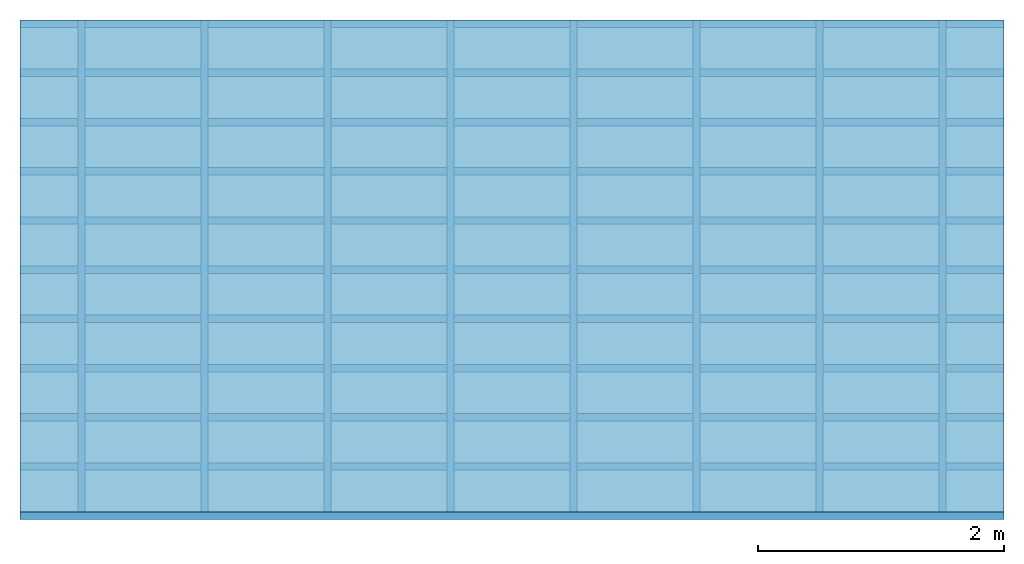
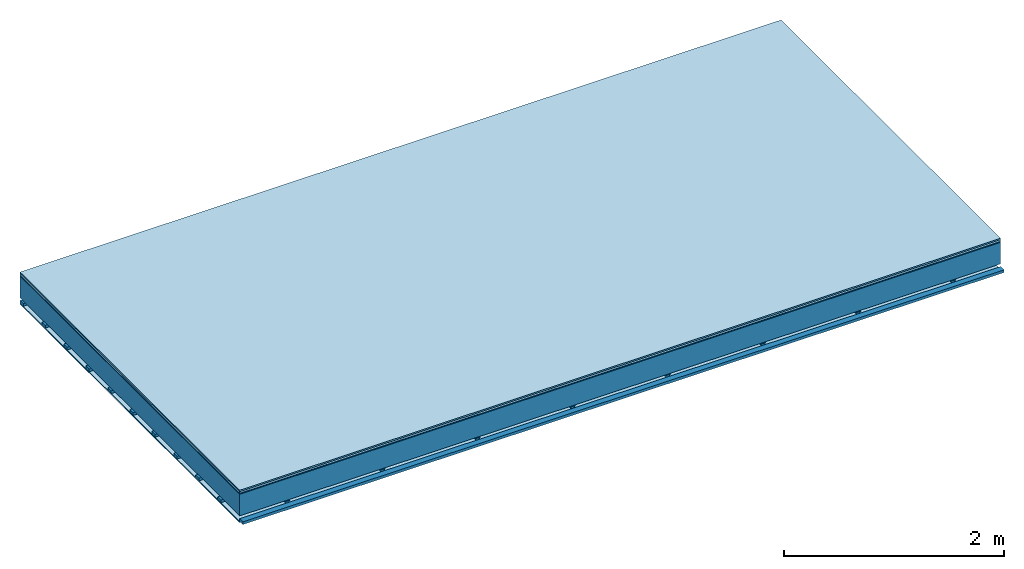
# One storey: 5 plates, 3 members, 1 element without a shape of its own.
"""IFC4 building model written with IfcOpenShell, lengths in metres."""

from ifc_helpers import new_model, si_unit, derived_unit, direction, frame, frame_2d, origin, origin_with_axes, place, context, project, spatial, polyline, rectangle, outline, extrude, material, layer, layer_set, type_object, element, aggregate, save


model = new_model("IFC4")

# Units and contexts
plan_context = context("Plan", 3, precision=1e-05, world=origin(), true_north=direction((0.0, 1.0)))
model_context = context("Model", 3, precision=1e-05, world=origin(), true_north=direction((0.0, 1.0)))
ifc_project = project(units=[si_unit("LENGTHUNIT", "METRE"), derived_unit("SOUNDPRESSUREUNIT", [(si_unit("PRESSUREUNIT", "PASCAL", prefix="MICRO"), 0)]), si_unit("ENERGYUNIT", "JOULE", prefix="MEGA"), si_unit("MASSUNIT", "GRAM", prefix="KILO"), derived_unit("THERMALTRANSMITTANCEUNIT", [(si_unit("POWERUNIT", "WATT"), 1), (si_unit("AREAUNIT", "SQUARE_METRE"), -1), (si_unit("THERMODYNAMICTEMPERATUREUNIT", "KELVIN"), -1)]), derived_unit("AREADENSITYUNIT", [(si_unit("MASSUNIT", "GRAM", prefix="KILO"), 1), (si_unit("AREAUNIT", "SQUARE_METRE"), -1)]), derived_unit("USERDEFINED", [(si_unit("ENERGYUNIT", "JOULE", prefix="MEGA"), 1), (si_unit("AREAUNIT", "SQUARE_METRE"), -1)])], contexts=[plan_context, model_context])

# Site, building, storey
site = spatial("IfcSite", under=ifc_project)
building_placement = place(None, origin())
building = spatial("IfcBuilding", under=site, at=building_placement)
storey_placement = place(building_placement, origin())
storey = spatial("IfcBuildingStorey", under=building, at=storey_placement)

# Slab, members, plates
ifc_material_1 = material(Category="11.013")
ifc_layer_1 = layer(ifc_material_1, 0.015, Name="Flooring")
ifc_material_2 = material(Category="03.007")
ifc_layer_2 = layer(ifc_material_2, 0.02, Name="On-material")
ifc_material_3 = material(Name="Wood fiber generic product", Category="10.009")
ifc_layer_3 = layer(ifc_material_3, 0.01, Name="Impact sound insulation")
ifc_material_4 = material(Name="no composite action")
ifc_layer_4 = layer(ifc_material_4, 0.0, Name="Bond")
ifc_layer_5 = layer(None, 0.24, Name="Supporting structure")
ifc_layer_6 = layer(ifc_material_4, 0.0, Name="Bond")
ifc_layer_7 = layer(None, 0.03, Name="Coupling")
ifc_layer_8 = layer(None, 0.03, Name="Battens / profiles")
ifc_material_5 = material(Name="Plasterboard type A", Category="03.008")
ifc_layer_9 = layer(ifc_material_5, 0.0125, Name="Ceiling covering 1st layer")
ifc_material_6 = material(Category="04.001")
ifc_layer_10 = layer(ifc_material_6, 0.003, Name="Surface / treatment")
ifc_layer_set = layer_set([ifc_layer_1, ifc_layer_2, ifc_layer_3, ifc_layer_4, ifc_layer_5, ifc_layer_6, ifc_layer_7, ifc_layer_8, ifc_layer_9, ifc_layer_10])
slab_type = type_object("IfcSlabType", Name="A2102", PredefinedType="NOTDEFINED", material=ifc_layer_set)
slab_placement = place(None, frame((0.0, 0.0, 0.0), z_axis=(0.0, 0.0, -1.0), x_axis=(1.0, 0.0, 0.0)))
slab = element("IfcSlab", 1, at=slab_placement, inside=storey, type_object=slab_type, material=ifc_layer_set, Name="Slab #1")
ifc_material_7 = material(Name="Solid timber panel")
member_1_placement = place(slab_placement, origin())
member_1 = element("IfcMember", 2, at=member_1_placement, material=ifc_material_7, Name="Supporting structure", context=plan_context, shape_type="SweptSolid", body=[
    extrude(rectangle(XDim=1.0, YDim=0.24, at=frame_2d((0.5, 0.12), x_axis=(1.0, 0.0))), frame((0.0, 4.0, 0.045), z_axis=(0.0, -1.0, 0.0), x_axis=(1.0, 0.0, 0.0)), (0.0, 0.0, 1.0), 4.0),
    extrude(rectangle(XDim=1.0, YDim=0.24, at=frame_2d((0.5, 0.12), x_axis=(1.0, 0.0))), frame((1.0, 4.0, 0.045), z_axis=(0.0, -1.0, 0.0), x_axis=(1.0, 0.0, 0.0)), (0.0, 0.0, 1.0), 4.0),
    extrude(rectangle(XDim=1.0, YDim=0.24, at=frame_2d((0.5, 0.12), x_axis=(1.0, 0.0))), frame((2.0, 4.0, 0.045), z_axis=(0.0, -1.0, 0.0), x_axis=(1.0, 0.0, 0.0)), (0.0, 0.0, 1.0), 4.0),
    extrude(rectangle(XDim=1.0, YDim=0.24, at=frame_2d((0.5, 0.12), x_axis=(1.0, 0.0))), frame((3.0, 4.0, 0.045), z_axis=(0.0, -1.0, 0.0), x_axis=(1.0, 0.0, 0.0)), (0.0, 0.0, 1.0), 4.0),
    extrude(rectangle(XDim=1.0, YDim=0.24, at=frame_2d((0.5, 0.12), x_axis=(1.0, 0.0))), frame((4.0, 4.0, 0.045), z_axis=(0.0, -1.0, 0.0), x_axis=(1.0, 0.0, 0.0)), (0.0, 0.0, 1.0), 4.0),
    extrude(rectangle(XDim=1.0, YDim=0.24, at=frame_2d((0.5, 0.12), x_axis=(1.0, 0.0))), frame((5.0, 4.0, 0.045), z_axis=(0.0, -1.0, 0.0), x_axis=(1.0, 0.0, 0.0)), (0.0, 0.0, 1.0), 4.0),
    extrude(rectangle(XDim=1.0, YDim=0.24, at=frame_2d((0.5, 0.12), x_axis=(1.0, 0.0))), frame((6.0, 4.0, 0.045), z_axis=(0.0, -1.0, 0.0), x_axis=(1.0, 0.0, 0.0)), (0.0, 0.0, 1.0), 4.0),
    extrude(rectangle(XDim=1.0, YDim=0.24, at=frame_2d((0.5, 0.12), x_axis=(1.0, 0.0))), frame((7.0, 4.0, 0.045), z_axis=(0.0, -1.0, 0.0), x_axis=(1.0, 0.0, 0.0)), (0.0, 0.0, 1.0), 4.0),
])
ifc_material_8 = material()
member_2_placement = place(slab_placement, origin())
member_2 = element("IfcMember", 3, at=member_2_placement, material=ifc_material_8, Name="Coupling", context=plan_context, shape_type="SweptSolid", body=[
    extrude(outline(polyline([(0.0, 0.0), (0.06, 0.0), (0.04, 0.02), (0.02, 0.02), (0.0, 0.0)])), frame((0.47, 4.0, 0.295), z_axis=(0.0, -1.0, 0.0), x_axis=(1.0, 0.0, 0.0)), (0.0, 0.0, 1.0), 4.0),
    extrude(outline(polyline([(0.0, 0.0), (0.06, 0.0), (0.04, 0.02), (0.02, 0.02), (0.0, 0.0)])), frame((1.47, 4.0, 0.295), z_axis=(0.0, -1.0, 0.0), x_axis=(1.0, 0.0, 0.0)), (0.0, 0.0, 1.0), 4.0),
    extrude(outline(polyline([(0.0, 0.0), (0.06, 0.0), (0.04, 0.02), (0.02, 0.02), (0.0, 0.0)])), frame((2.47, 4.0, 0.295), z_axis=(0.0, -1.0, 0.0), x_axis=(1.0, 0.0, 0.0)), (0.0, 0.0, 1.0), 4.0),
    extrude(outline(polyline([(0.0, 0.0), (0.06, 0.0), (0.04, 0.02), (0.02, 0.02), (0.0, 0.0)])), frame((3.47, 4.0, 0.295), z_axis=(0.0, -1.0, 0.0), x_axis=(1.0, 0.0, 0.0)), (0.0, 0.0, 1.0), 4.0),
    extrude(outline(polyline([(0.0, 0.0), (0.06, 0.0), (0.04, 0.02), (0.02, 0.02), (0.0, 0.0)])), frame((4.47, 4.0, 0.295), z_axis=(0.0, -1.0, 0.0), x_axis=(1.0, 0.0, 0.0)), (0.0, 0.0, 1.0), 4.0),
    extrude(outline(polyline([(0.0, 0.0), (0.06, 0.0), (0.04, 0.02), (0.02, 0.02), (0.0, 0.0)])), frame((5.47, 4.0, 0.295), z_axis=(0.0, -1.0, 0.0), x_axis=(1.0, 0.0, 0.0)), (0.0, 0.0, 1.0), 4.0),
    extrude(outline(polyline([(0.0, 0.0), (0.06, 0.0), (0.04, 0.02), (0.02, 0.02), (0.0, 0.0)])), frame((6.47, 4.0, 0.295), z_axis=(0.0, -1.0, 0.0), x_axis=(1.0, 0.0, 0.0)), (0.0, 0.0, 1.0), 4.0),
    extrude(outline(polyline([(0.0, 0.0), (0.06, 0.0), (0.04, 0.02), (0.02, 0.02), (0.0, 0.0)])), frame((7.47, 4.0, 0.295), z_axis=(0.0, -1.0, 0.0), x_axis=(1.0, 0.0, 0.0)), (0.0, 0.0, 1.0), 4.0),
])
member_3_placement = place(slab_placement, origin())
member_3 = element("IfcMember", 4, at=member_3_placement, material=ifc_material_8, Name="Battens / profiles", context=plan_context, shape_type="SweptSolid", body=[
    extrude(rectangle(XDim=0.06, YDim=0.03, at=frame_2d((0.03, 0.015), x_axis=(1.0, 0.0))), frame((0.0, 0.0, 0.315), z_axis=(1.0, 0.0, 0.0), x_axis=(0.0, 1.0, 0.0)), (0.0, 0.0, 1.0), 8.0),
    extrude(rectangle(XDim=0.06, YDim=0.03, at=frame_2d((0.03, 0.015), x_axis=(1.0, 0.0))), frame((0.0, 0.4, 0.315), z_axis=(1.0, 0.0, 0.0), x_axis=(0.0, 1.0, 0.0)), (0.0, 0.0, 1.0), 8.0),
    extrude(rectangle(XDim=0.06, YDim=0.03, at=frame_2d((0.03, 0.015), x_axis=(1.0, 0.0))), frame((0.0, 0.8, 0.315), z_axis=(1.0, 0.0, 0.0), x_axis=(0.0, 1.0, 0.0)), (0.0, 0.0, 1.0), 8.0),
    extrude(rectangle(XDim=0.06, YDim=0.03, at=frame_2d((0.03, 0.015), x_axis=(1.0, 0.0))), frame((0.0, 1.2, 0.315), z_axis=(1.0, 0.0, 0.0), x_axis=(0.0, 1.0, 0.0)), (0.0, 0.0, 1.0), 8.0),
    extrude(rectangle(XDim=0.06, YDim=0.03, at=frame_2d((0.03, 0.015), x_axis=(1.0, 0.0))), frame((0.0, 1.6, 0.315), z_axis=(1.0, 0.0, 0.0), x_axis=(0.0, 1.0, 0.0)), (0.0, 0.0, 1.0), 8.0),
    extrude(rectangle(XDim=0.06, YDim=0.03, at=frame_2d((0.03, 0.015), x_axis=(1.0, 0.0))), frame((0.0, 2.0, 0.315), z_axis=(1.0, 0.0, 0.0), x_axis=(0.0, 1.0, 0.0)), (0.0, 0.0, 1.0), 8.0),
    extrude(rectangle(XDim=0.06, YDim=0.03, at=frame_2d((0.03, 0.015), x_axis=(1.0, 0.0))), frame((0.0, 2.4, 0.315), z_axis=(1.0, 0.0, 0.0), x_axis=(0.0, 1.0, 0.0)), (0.0, 0.0, 1.0), 8.0),
    extrude(rectangle(XDim=0.06, YDim=0.03, at=frame_2d((0.03, 0.015), x_axis=(1.0, 0.0))), frame((0.0, 2.8, 0.315), z_axis=(1.0, 0.0, 0.0), x_axis=(0.0, 1.0, 0.0)), (0.0, 0.0, 1.0), 8.0),
    extrude(rectangle(XDim=0.06, YDim=0.03, at=frame_2d((0.03, 0.015), x_axis=(1.0, 0.0))), frame((0.0, 3.2, 0.315), z_axis=(1.0, 0.0, 0.0), x_axis=(0.0, 1.0, 0.0)), (0.0, 0.0, 1.0), 8.0),
    extrude(rectangle(XDim=0.06, YDim=0.03, at=frame_2d((0.03, 0.015), x_axis=(1.0, 0.0))), frame((0.0, 3.6, 0.315), z_axis=(1.0, 0.0, 0.0), x_axis=(0.0, 1.0, 0.0)), (0.0, 0.0, 1.0), 8.0),
    extrude(rectangle(XDim=0.06, YDim=0.03, at=frame_2d((0.03, 0.015), x_axis=(1.0, 0.0))), frame((0.0, 4.0, 0.315), z_axis=(1.0, 0.0, 0.0), x_axis=(0.0, 1.0, 0.0)), (0.0, 0.0, 1.0), 8.0),
])
plate_1_placement = place(slab_placement, origin())
plate_1 = element("IfcPlate", 5, at=plate_1_placement, material=ifc_material_1, Name="Flooring", context=plan_context, shape_type="SweptSolid", body=[
    extrude(rectangle(XDim=8.0, YDim=4.0, at=frame_2d((4.0, 2.0), x_axis=(1.0, 0.0))), origin_with_axes(), (0.0, 0.0, 1.0), 0.015),
])
plate_2_placement = place(slab_placement, origin())
plate_2 = element("IfcPlate", 6, at=plate_2_placement, material=ifc_material_2, Name="On-material", context=plan_context, shape_type="SweptSolid", body=[
    extrude(rectangle(XDim=8.0, YDim=4.0, at=frame_2d((4.0, 2.0), x_axis=(1.0, 0.0))), frame((0.0, 0.0, 0.015), z_axis=(0.0, 0.0, 1.0), x_axis=(1.0, 0.0, 0.0)), (0.0, 0.0, 1.0), 0.02),
])
plate_3_placement = place(slab_placement, origin())
plate_3 = element("IfcPlate", 7, at=plate_3_placement, material=ifc_material_3, Name="Impact sound insulation", context=plan_context, shape_type="SweptSolid", body=[
    extrude(rectangle(XDim=8.0, YDim=4.0, at=frame_2d((4.0, 2.0), x_axis=(1.0, 0.0))), frame((0.0, 0.0, 0.035), z_axis=(0.0, 0.0, 1.0), x_axis=(1.0, 0.0, 0.0)), (0.0, 0.0, 1.0), 0.01),
])
plate_4_placement = place(slab_placement, origin())
plate_4 = element("IfcPlate", 8, at=plate_4_placement, material=ifc_material_5, Name="Ceiling covering 1st layer", context=plan_context, shape_type="SweptSolid", body=[
    extrude(rectangle(XDim=8.0, YDim=4.0, at=frame_2d((4.0, 2.0), x_axis=(1.0, 0.0))), frame((0.0, 0.0, 0.345), z_axis=(0.0, 0.0, 1.0), x_axis=(1.0, 0.0, 0.0)), (0.0, 0.0, 1.0), 0.0125),
])
plate_5_placement = place(slab_placement, origin())
plate_5 = element("IfcPlate", 9, at=plate_5_placement, material=ifc_material_6, Name="Surface / treatment", context=plan_context, shape_type="SweptSolid", body=[
    extrude(rectangle(XDim=8.0, YDim=4.0, at=frame_2d((4.0, 2.0), x_axis=(1.0, 0.0))), frame((0.0, 0.0, 0.3575), z_axis=(0.0, 0.0, 1.0), x_axis=(1.0, 0.0, 0.0)), (0.0, 0.0, 1.0), 0.003),
])
aggregate(slab, [plate_1, plate_2, plate_3, member_1, member_2, member_3, plate_4, plate_5])

save(model, "model.ifc")
